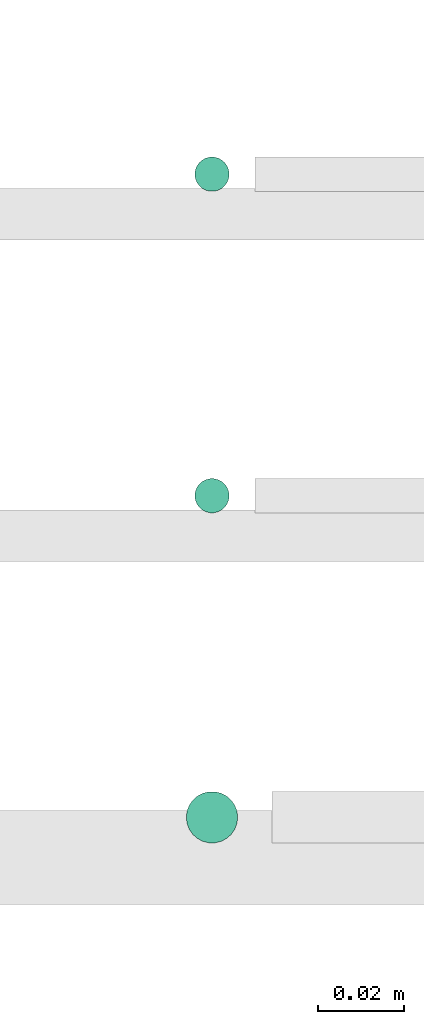
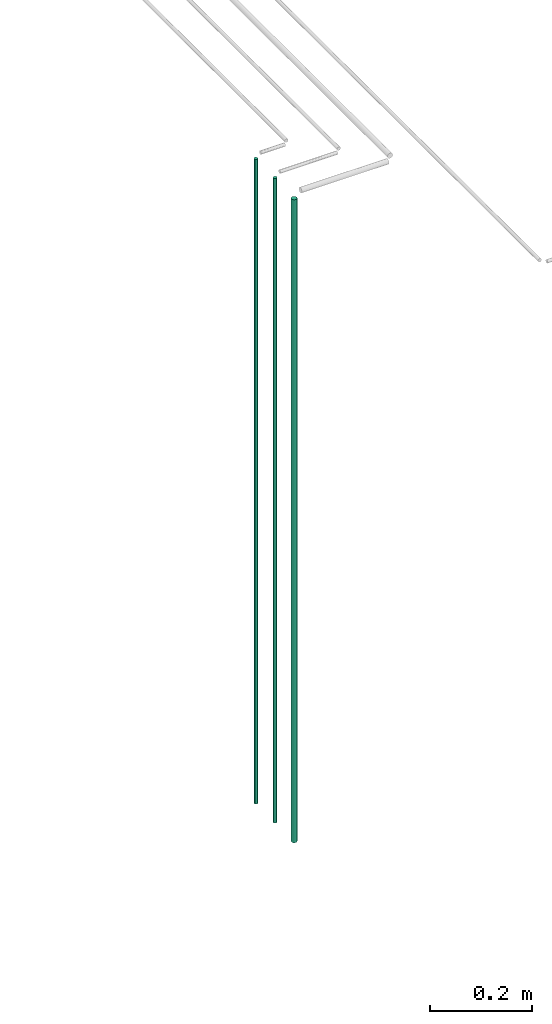
# One storey, part 20 of 331: 3 flow segments.
"""IFC2X3 building model written with IfcOpenShell, lengths in millimetres."""

import ifcopenshell
import ifcopenshell.guid

model = None  # the IFC model being written
_history = None  # IfcOwnerHistory: only IFC2X3 demands one
_inside = {}  # id of a spatial element -> (the spatial element, [elements in it])
_under = {}  # id of a project, library or spatial element -> (it, [spatial elements below it])
_declared = {}  # id of a project -> (the project, [libraries it declares])
_typed = {}  # id of a type object -> (the type object, [elements of that type])
_made_of = {}  # id of a material, layer set ... -> (it, [elements and type objects made of it])


def new_model(schema):
    """Start an empty IFC model of exactly this schema.

    Asked for "IFC4X3", IfcOpenShell would pick the latest addendum, in which some entities
    have other attributes; the version numbers below select the first issue.
    IFC2X3 requires an IfcOwnerHistory on every rooted entity: one is made here for all.
    """
    global model, _history
    if schema == "IFC4X3":
        model = ifcopenshell.file(schema_version=(4, 3, 0, 0))
    else:
        model = ifcopenshell.file(schema=schema)
    _inside.clear()
    _under.clear()
    _declared.clear()
    _typed.clear()
    _made_of.clear()
    _history = None
    if model.schema == "IFC2X3":
        org = make("IfcOrganization", Name="unknown")
        user = make(
            "IfcPersonAndOrganization",
            ThePerson=make("IfcPerson", FamilyName="unknown"),
            TheOrganization=org,
        )
        app = make(
            "IfcApplication",
            ApplicationDeveloper=org,
            Version="unknown",
            ApplicationFullName="unknown",
            ApplicationIdentifier="unknown",
        )
        _history = make(
            "IfcOwnerHistory",
            OwningUser=user,
            OwningApplication=app,
            ChangeAction="ADDED",
            CreationDate=0,
        )
    return model


def make(cls, **values):
    """One entity of the class cls with the attributes given. An attribute that is None is left unset."""
    return model.create_entity(
        cls, **{name: value for name, value in values.items() if value is not None}
    )


def entity(cls, *values):
    """Any entity or typed value of the class cls, its attributes in the order of the schema. None: left unset."""
    e = model.create_entity(cls)
    for i, value in enumerate(values):
        if value is not None:
            e[i] = value
    return e


def rooted(cls, **values):
    """An entity with a GlobalId (a new one), such as an element, a storey or a relation."""
    return make(cls, GlobalId=ifcopenshell.guid.new(), OwnerHistory=_history, **values)


def si_unit(unit_type, name, prefix=None):
    """IfcSIUnit, for example si_unit("LENGTHUNIT", "METRE", prefix="MILLI")."""
    return make("IfcSIUnit", UnitType=unit_type, Prefix=prefix, Name=name)


def converted_unit(unit_type, name, factor, base, dimensions=None, offset=None):
    """IfcConversionBasedUnit, such as the inch: factor (a typed value) times the base unit."""
    return make(
        "IfcConversionBasedUnit"
        if offset is None
        else "IfcConversionBasedUnitWithOffset",
        ConversionOffset=offset,
        Dimensions=None
        if dimensions is None
        else entity("IfcDimensionalExponents", *dimensions),
        UnitType=unit_type,
        Name=name,
        ConversionFactor=make(
            "IfcMeasureWithUnit", ValueComponent=factor, UnitComponent=base
        ),
    )


def derived_unit(unit_type, elements):
    """IfcDerivedUnit: a product of units, each with its exponent."""
    return make(
        "IfcDerivedUnit",
        Elements=[
            make("IfcDerivedUnitElement", Unit=unit, Exponent=power)
            for unit, power in elements
        ],
        UnitType=unit_type,
    )


def assignment(units):
    """IfcUnitAssignment: the units of a project."""
    return None if units is None else make("IfcUnitAssignment", Units=units)


def point(xyz):
    """IfcCartesianPoint."""
    return None if xyz is None else make("IfcCartesianPoint", Coordinates=xyz)


def direction(xyz):
    """IfcDirection."""
    return None if xyz is None else make("IfcDirection", DirectionRatios=xyz)


def frame(location, z_axis=None, x_axis=None):
    """IfcAxis2Placement3D, a coordinate frame: its origin and axes. An axis left out is left unset."""
    return make(
        "IfcAxis2Placement3D",
        Location=point(location),
        Axis=direction(z_axis),
        RefDirection=direction(x_axis),
    )


def frame_2d(location, x_axis=None):
    """IfcAxis2Placement2D, a coordinate frame in the plane: its origin and x axis."""
    return make(
        "IfcAxis2Placement2D", Location=point(location), RefDirection=direction(x_axis)
    )


def origin():
    """The frame at (0, 0, 0) with its axes left unset."""
    return frame((0.0, 0.0, 0.0))


def place(relative_to, where):
    """IfcLocalPlacement: puts the frame where relative to a parent placement (None: the world)."""
    return make(
        "IfcLocalPlacement", PlacementRelTo=relative_to, RelativePlacement=where
    )


def context(
    kind, dimensions, precision=None, world=None, true_north=None, identifier=None
):
    """IfcGeometricRepresentationContext, for example the 3D "Model" context."""
    return make(
        "IfcGeometricRepresentationContext",
        ContextIdentifier=identifier,
        ContextType=kind,
        CoordinateSpaceDimension=dimensions,
        Precision=precision,
        WorldCoordinateSystem=world,
        TrueNorth=true_north,
    )


def subcontext(parent, identifier, kind, view, scale=None):
    """IfcGeometricRepresentationSubContext, for example "Body" below "Model"."""
    return make(
        "IfcGeometricRepresentationSubContext",
        ContextIdentifier=identifier,
        ContextType=kind,
        ParentContext=parent,
        TargetScale=scale,
        TargetView=view,
    )


def project(units=None, contexts=None):
    """IfcProject with its units and contexts."""
    return rooted(
        "IfcProject",
        Name="project",
        RepresentationContexts=contexts,
        UnitsInContext=assignment(units),
    )


def spatial(cls, under=None, at=None, **own):
    """A site, building, storey or space (cls), placed at a placement, below another one or the project."""
    s = rooted(cls, ObjectPlacement=at, **own)
    if under is not None:
        _under.setdefault(under.id(), (under, []))[1].append(s)
    return s


def profile(cls, at=None, kind="AREA", **sizes):
    """A parametric profile (cls). Its sizes go by their IFC names, for example OverallWidth=200.0."""
    return make(cls, ProfileType=kind, Position=at, **sizes)


def circle(**sizes):
    """IfcCircleProfileDef."""
    return profile("IfcCircleProfileDef", **sizes)


def extrude(swept, where, along, depth):
    """IfcExtrudedAreaSolid: the profile swept, set in the frame where, extruded along a direction by depth."""
    return make(
        "IfcExtrudedAreaSolid",
        SweptArea=swept,
        Position=where,
        ExtrudedDirection=direction(along),
        Depth=depth,
    )


def shape(context_of_items, identifier, shape_type, items):
    """IfcShapeRepresentation: the items that make up one representation, for example the "Body"."""
    return make(
        "IfcShapeRepresentation",
        ContextOfItems=context_of_items,
        RepresentationIdentifier=identifier,
        RepresentationType=shape_type,
        Items=items,
    )


def made_of(thing, what):
    """Note that an element or type object is made of a material, layer set ...; save() writes the relation."""
    if what is not None:
        _made_of.setdefault(what.id(), (what, []))[1].append(thing)
    return thing


def type_object(cls, material=None, **own):
    """A type object (cls), such as IfcWallType, which elements share."""
    return made_of(rooted(cls, **own), material)


def element(
    cls,
    number,
    at=None,
    inside=None,
    cuts=None,
    type_object=None,
    material=None,
    context=None,
    identifier="Body",
    shape_type=None,
    held_by="IfcProductDefinitionShape",
    body=None,
    shapes=None,
    **own,
):
    """One element of the class cls, such as IfcWall. Its Tag is "e" and its number.

    at: its placement. inside: the storey or other place that contains it. cuts: it is an
    opening in that element (IfcRelVoidsElement). A single representation is given by context,
    identifier, shape_type and body (its items); several are given by shapes. held_by: the class
    of the entity that holds the representations. save() writes the other relations.
    """
    e = rooted(cls, Tag="e%d" % number, ObjectPlacement=at, **own)
    if body is not None:
        shapes = [shape(context, identifier, shape_type, body)]
    if shapes is not None:
        e.Representation = make(held_by, Representations=shapes)
    if inside is not None:
        _inside.setdefault(inside.id(), (inside, []))[1].append(e)
    if cuts is not None:
        rooted(
            "IfcRelVoidsElement", RelatingBuildingElement=cuts, RelatedOpeningElement=e
        )
    if type_object is not None:
        _typed.setdefault(type_object.id(), (type_object, []))[1].append(e)
    return made_of(e, material)


def aggregate(whole, parts):
    """IfcRelAggregates: a whole, such as a stair, and the parts it consists of."""
    return rooted("IfcRelAggregates", RelatingObject=whole, RelatedObjects=parts)


def save(model, path):
    """Write the relations noted so far, then the file.

    IfcRelAggregates (storeys below a building ...), IfcRelContainedInSpatialStructure (elements
    in a storey), IfcRelDefinesByType, IfcRelAssociatesMaterial and IfcRelDeclares: one each for
    every whole, place, type object, material and project.
    """
    for whole, parts in _under.values():
        aggregate(whole, parts)
    for where, things in _inside.values():
        rooted(
            "IfcRelContainedInSpatialStructure",
            RelatedElements=things,
            RelatingStructure=where,
        )
    for kind, things in _typed.values():
        rooted("IfcRelDefinesByType", RelatedObjects=things, RelatingType=kind)
    for what, things in _made_of.values():
        rooted("IfcRelAssociatesMaterial", RelatedObjects=things, RelatingMaterial=what)
    for by, libraries in _declared.values():
        rooted("IfcRelDeclares", RelatingContext=by, RelatedDefinitions=libraries)
    model.write(path)


model = new_model("IFC2X3")

# Units and contexts
model_context = context("Model", 3, precision=0.01, world=origin(), true_north=direction((6.12303176911189e-17, 1.0)))
body_context = subcontext(model_context, "Body", "Model", "MODEL_VIEW")
ifc_project = project(units=[si_unit("LENGTHUNIT", "METRE", prefix="MILLI"), si_unit("AREAUNIT", "SQUARE_METRE"), si_unit("VOLUMEUNIT", "CUBIC_METRE"), converted_unit("PLANEANGLEUNIT", "DEGREE", entity("IfcRatioMeasure", 0.0174532925199433), si_unit("PLANEANGLEUNIT", "RADIAN"), dimensions=[0, 0, 0, 0, 0, 0, 0]), si_unit("MASSUNIT", "GRAM", prefix="KILO"), derived_unit("MASSDENSITYUNIT", [(si_unit("MASSUNIT", "GRAM", prefix="KILO"), 1), (si_unit("LENGTHUNIT", "METRE"), -3)]), derived_unit("MOMENTOFINERTIAUNIT", [(si_unit("LENGTHUNIT", "METRE"), 4)]), si_unit("TIMEUNIT", "SECOND"), si_unit("FREQUENCYUNIT", "HERTZ"), si_unit("THERMODYNAMICTEMPERATUREUNIT", "DEGREE_CELSIUS"), derived_unit("THERMALTRANSMITTANCEUNIT", [(si_unit("MASSUNIT", "GRAM", prefix="KILO"), 1), (si_unit("THERMODYNAMICTEMPERATUREUNIT", "KELVIN"), -1), (si_unit("TIMEUNIT", "SECOND"), -3)]), derived_unit("VOLUMETRICFLOWRATEUNIT", [(si_unit("LENGTHUNIT", "METRE"), 3), (si_unit("TIMEUNIT", "SECOND"), -1)]), derived_unit("MASSFLOWRATEUNIT", [(si_unit("MASSUNIT", "GRAM", prefix="KILO"), 1), (si_unit("TIMEUNIT", "SECOND"), -1)]), derived_unit("ROTATIONALFREQUENCYUNIT", [(si_unit("TIMEUNIT", "SECOND"), -1)]), si_unit("ELECTRICCURRENTUNIT", "AMPERE"), si_unit("ELECTRICVOLTAGEUNIT", "VOLT"), si_unit("POWERUNIT", "WATT"), si_unit("FORCEUNIT", "NEWTON", prefix="KILO"), si_unit("ILLUMINANCEUNIT", "LUX"), si_unit("LUMINOUSFLUXUNIT", "LUMEN"), si_unit("LUMINOUSINTENSITYUNIT", "CANDELA"), derived_unit("USERDEFINED", [(si_unit("MASSUNIT", "GRAM", prefix="KILO"), -1), (si_unit("LENGTHUNIT", "METRE"), -2), (si_unit("TIMEUNIT", "SECOND"), 3), (si_unit("LUMINOUSFLUXUNIT", "LUMEN"), 1)]), derived_unit("LINEARVELOCITYUNIT", [(si_unit("LENGTHUNIT", "METRE"), 1), (si_unit("TIMEUNIT", "SECOND"), -1)]), si_unit("PRESSUREUNIT", "PASCAL"), derived_unit("USERDEFINED", [(si_unit("LENGTHUNIT", "METRE"), -2), (si_unit("MASSUNIT", "GRAM", prefix="KILO"), 1), (si_unit("TIMEUNIT", "SECOND"), -2)]), derived_unit("LINEARFORCEUNIT", [(si_unit("MASSUNIT", "GRAM", prefix="KILO"), 1), (si_unit("LENGTHUNIT", "METRE"), 1), (si_unit("TIMEUNIT", "SECOND"), -2), (si_unit("LENGTHUNIT", "METRE"), -1)]), derived_unit("PLANARFORCEUNIT", [(si_unit("MASSUNIT", "GRAM", prefix="KILO"), 1), (si_unit("LENGTHUNIT", "METRE"), 1), (si_unit("TIMEUNIT", "SECOND"), -2), (si_unit("LENGTHUNIT", "METRE"), -2)])], contexts=[model_context])

# Site, building, storey
site_placement = place(None, frame((0.0, -0.00077364408347762, 0.0)))
site = spatial("IfcSite", under=ifc_project, at=site_placement, CompositionType="ELEMENT")
building_placement = place(site_placement, origin())
building = spatial("IfcBuilding", under=site, at=building_placement, CompositionType="ELEMENT")
storey_placement = place(building_placement, origin())
storey = spatial("IfcBuildingStorey", under=building, at=storey_placement, CompositionType="ELEMENT", Elevation=0.0)

# Flow segments
pipe_segment_type = type_object("IfcPipeSegmentType", PredefinedType="NOTDEFINED")
for number, where in (
    (1, (40065.3415012262, 8679.40472776427, 5700.0)),
    (2, (40065.3415012262, 8604.40472776427, 5700.0)),
):
    element("IfcFlowSegment", number, at=place(storey_placement, frame(where)), inside=storey, type_object=pipe_segment_type, context=body_context, shape_type="SweptSolid", body=[
        extrude(circle(Radius=4.0, at=frame_2d((0.0, -1.08286712929839e-12), x_axis=(1.0, 0.0))), frame((5.59527223591499, 5.59527223591716, 0.0)), (0.0, 0.0, 1.0), 1540.0),
    ])
flow_segment_placement = place(storey_placement, frame((40063.3415012262, 8527.40472776427, 5700.0)))
element("IfcFlowSegment", 3, at=flow_segment_placement, inside=storey, type_object=pipe_segment_type, context=body_context, shape_type="SweptSolid", body=[
    extrude(circle(Radius=6.0, at=frame_2d((0.0, -1.08286712929839e-12), x_axis=(1.0, 0.0))), frame((7.59527223591454, 7.5952722359167, 0.0)), (0.0, 0.0, 1.0), 1536.0),
])

save(model, "model.ifc")
